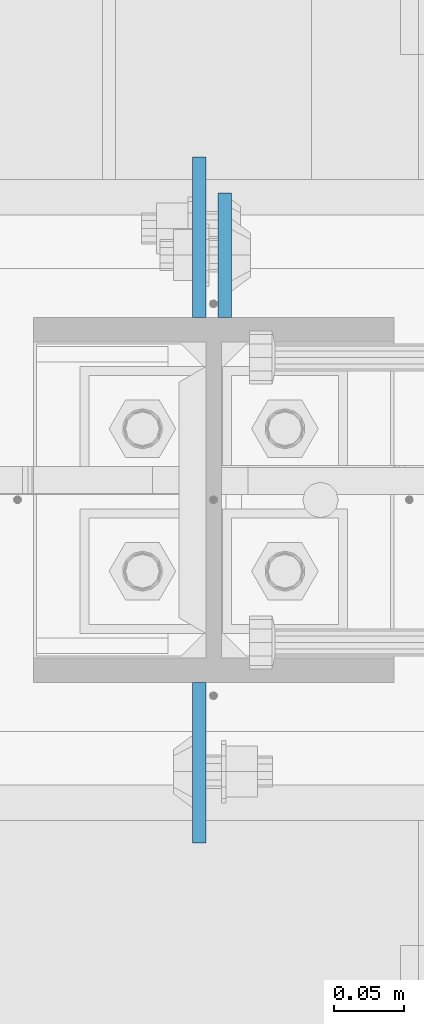
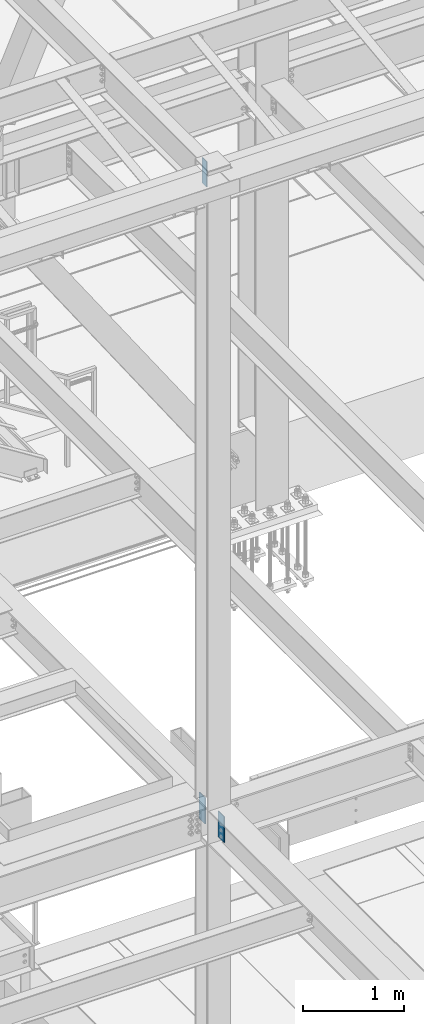
# One storey, part 1468 of 3843: 3 columns, 1 element without a shape of its own.
"""IFC2X3 building model written with IfcOpenShell, lengths in millimetres."""

from ifc_helpers import new_model, si_unit, frame, origin_with_axes, place, context, subcontext, project, spatial, faceted_brep, material, type_object, element, aggregate, save


model = new_model("IFC2X3")

# Units and contexts
model_context = context("Model", 3, precision=1e-05, world=origin_with_axes())
body_context = subcontext(model_context, "Body", "Model", "MODEL_VIEW")
ifc_project = project(units=[si_unit("LENGTHUNIT", "METRE", prefix="MILLI"), si_unit("AREAUNIT", "SQUARE_METRE"), si_unit("VOLUMEUNIT", "CUBIC_METRE"), si_unit("MASSUNIT", "GRAM", prefix="KILO"), si_unit("TIMEUNIT", "SECOND"), si_unit("PLANEANGLEUNIT", "RADIAN"), si_unit("SOLIDANGLEUNIT", "STERADIAN"), si_unit("THERMODYNAMICTEMPERATUREUNIT", "DEGREE_CELSIUS"), si_unit("LUMINOUSINTENSITYUNIT", "LUMEN")], contexts=[model_context])

# Site, building, storey
site_placement = place(None, origin_with_axes())
site = spatial("IfcSite", under=ifc_project, at=site_placement, CompositionType="ELEMENT")
building_placement = place(site_placement, origin_with_axes())
building = spatial("IfcBuilding", under=site, at=building_placement, Name="Undefined", CompositionType="ELEMENT")
storey_placement = place(building_placement, origin_with_axes())
storey = spatial("IfcBuildingStorey", under=building, at=storey_placement, Name="Undefined", CompositionType="ELEMENT", Elevation=0.0)

# Assembly, columns
assembly_placement = place(storey_placement, origin_with_axes())
assembly = element("IfcElementAssembly", 1, at=assembly_placement, inside=storey, Name="COLUMN", AssemblyPlace="NOTDEFINED", PredefinedType="RIGID_FRAME")
ifc_material = material(Name="STEEL/A572-50")
column_type_1 = type_object("IfcColumnType", PredefinedType="NOTDEFINED")
column_1_placement = place(assembly_placement, frame((55938.7374999523, 15173.325, 42125.8999993376), z_axis=(0.0, -1.0, 0.0), x_axis=(0.0, 0.0, 1.0)))
column_1 = element("IfcColumn", 2, at=column_1_placement, type_object=column_type_1, material=ifc_material, Name="PLATE", context=body_context, shape_type="Brep", body=[
    faceted_brep([(0.0, 4.76249999999709, -44.4500000000007), (0.0, 4.76249999999709, 44.4500000000007), (304.799999999996, 4.76249999999709, 44.4500000000007), (304.799999999996, 4.76249999999709, -44.4500000000007), (0.0, -4.76249999999709, 44.4500000000007), (304.799999999996, -4.76249999999709, 44.4500000000007), (0.0, -4.76249999999709, -44.4500000000007), (304.799999999996, -4.76249999999709, -44.4500000000007)], [[[0, 1, 2, 3]], [[1, 4, 5, 2]], [[4, 6, 7, 5]], [[6, 0, 3, 7]], [[5, 7, 3, 2]], [[6, 4, 1, 0]]]),
])
column_type_2 = type_object("IfcColumnType", PredefinedType="NOTDEFINED")
column_2_placement = place(assembly_placement, frame((55920.4814997673, 15186.025, 34442.3999987957), z_axis=(0.0, -1.0, 0.0), x_axis=(0.0, 0.0, 1.0)))
column_2 = element("IfcColumn", 3, at=column_2_placement, type_object=column_type_2, material=ifc_material, Name="PLATE", context=body_context, shape_type="Brep", body=[
    faceted_brep([(0.0, 4.76249999999709, -57.1500000000015), (0.0, 4.76249999999709, 57.1500000000015), (317.5, 4.76249999999709, 57.1499999999996), (317.5, 4.76249999999709, -57.1499999999996), (0.0, -4.76249999999709, 57.1500000000015), (317.5, -4.76249999999709, 57.1499999999996), (0.0, -4.76249999999709, -57.1500000000015), (317.5, -4.76249999999709, -57.1499999999996)], [[[0, 1, 2, 3]], [[1, 4, 5, 2]], [[4, 6, 7, 5]], [[6, 0, 3, 7]], [[5, 7, 3, 2]], [[6, 4, 1, 0]]]),
])
column_3_placement = place(assembly_placement, frame((55920.4814997673, 14811.375, 34442.3999987956), z_axis=(0.0, 1.0, 0.0), x_axis=(0.0, 0.0, 1.0)))
column_3 = element("IfcColumn", 4, at=column_3_placement, type_object=column_type_2, material=ifc_material, Name="PLATE", context=body_context, shape_type="Brep", body=[
    faceted_brep([(0.0, 4.76249999999709, -57.1500000000015), (0.0, 4.76249999999709, 57.1500000000015), (317.5, 4.76249999999709, 57.1499999999996), (317.5, 4.76249999999709, -57.1499999999996), (0.0, -4.76249999999709, 57.1500000000015), (317.5, -4.76249999999709, 57.1499999999996), (0.0, -4.76249999999709, -57.1500000000015), (317.5, -4.76249999999709, -57.1499999999996)], [[[0, 1, 2, 3]], [[1, 4, 5, 2]], [[4, 6, 7, 5]], [[6, 0, 3, 7]], [[5, 7, 3, 2]], [[6, 4, 1, 0]]]),
])
aggregate(assembly, [column_1, column_2, column_3])

save(model, "model.ifc")
